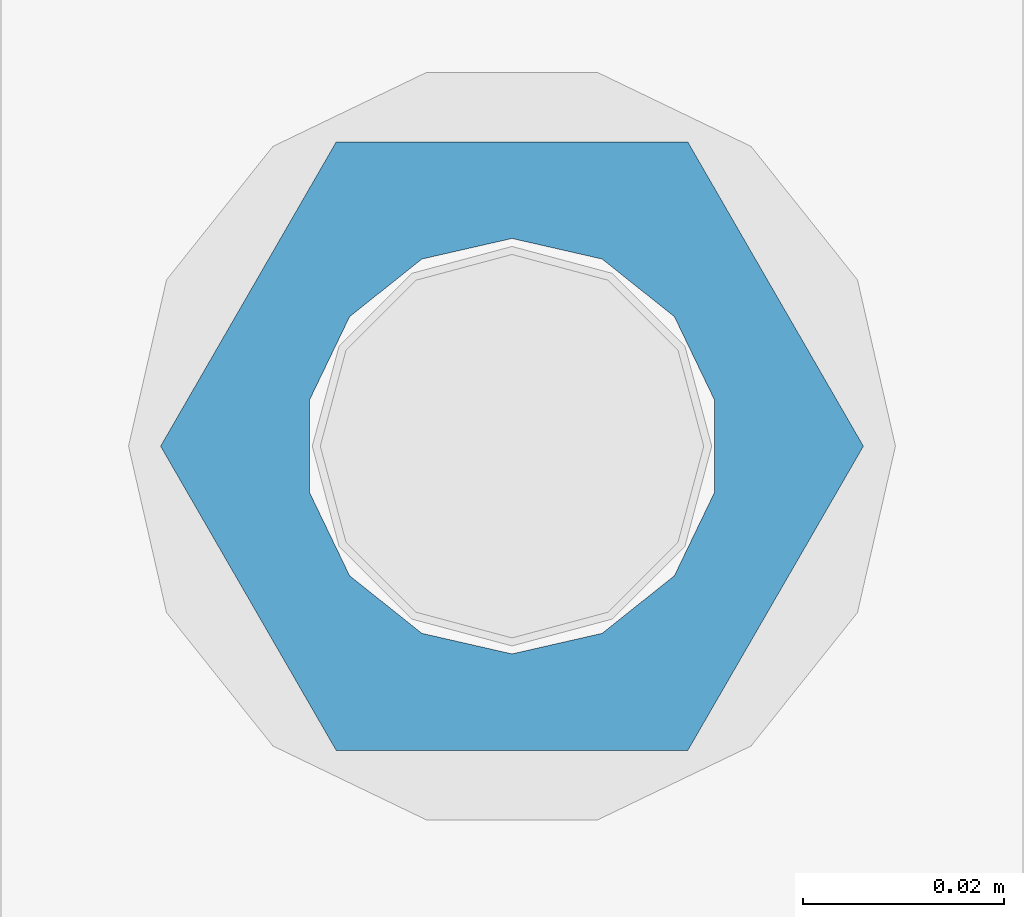
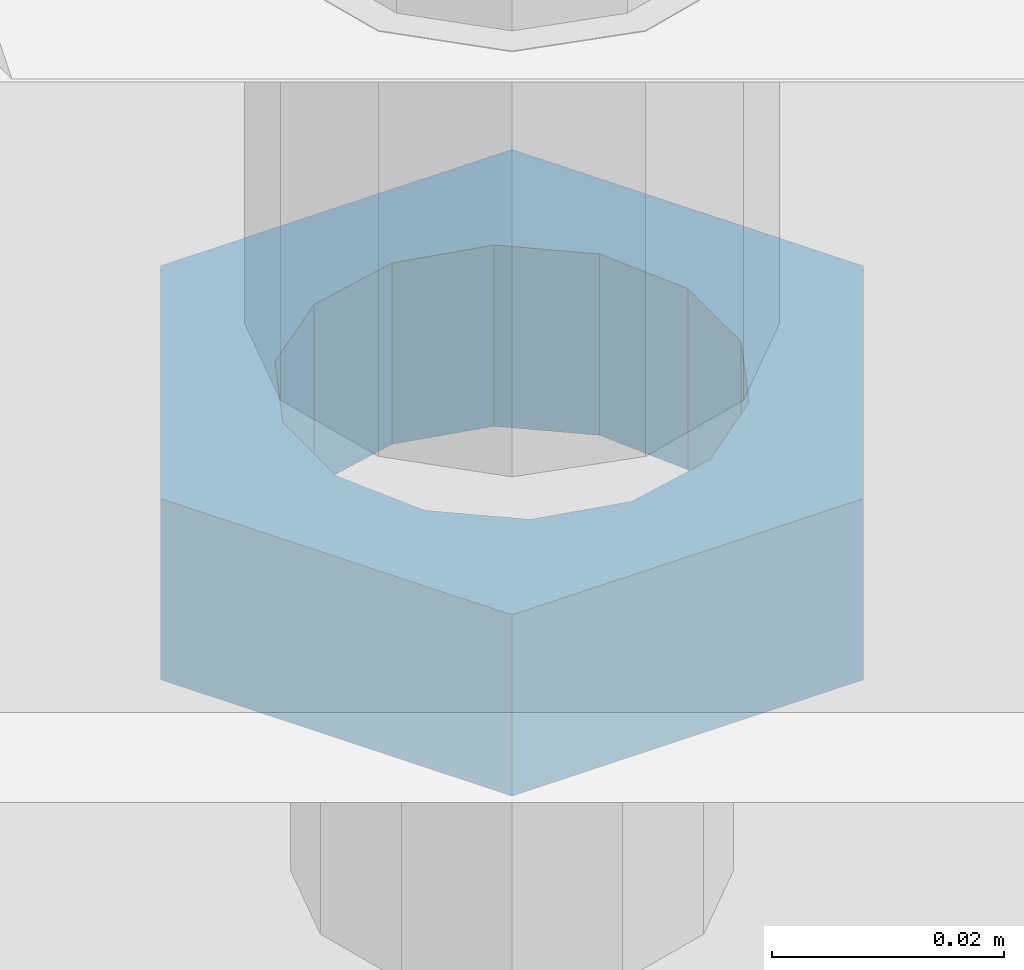
# One storey, part 1391 of 1763: 1 beam, 1 element without a shape of its own.
"""IFC2X3 building model written with IfcOpenShell, lengths in millimetres."""

from ifc_helpers import new_model, si_unit, frame, origin_with_axes, place, context, subcontext, project, spatial, faceted_brep, material, type_object, element, aggregate, save


model = new_model("IFC2X3")

# Units and contexts
model_context = context("Model", 3, precision=1e-05, world=origin_with_axes())
body_context = subcontext(model_context, "Body", "Model", "MODEL_VIEW")
ifc_project = project(units=[si_unit("LENGTHUNIT", "METRE", prefix="MILLI"), si_unit("AREAUNIT", "SQUARE_METRE"), si_unit("VOLUMEUNIT", "CUBIC_METRE"), si_unit("MASSUNIT", "GRAM", prefix="KILO"), si_unit("TIMEUNIT", "SECOND"), si_unit("PLANEANGLEUNIT", "RADIAN"), si_unit("SOLIDANGLEUNIT", "STERADIAN"), si_unit("THERMODYNAMICTEMPERATUREUNIT", "DEGREE_CELSIUS"), si_unit("LUMINOUSINTENSITYUNIT", "LUMEN")], contexts=[model_context])

# Site, building, storey
site_placement = place(None, origin_with_axes())
site = spatial("IfcSite", under=ifc_project, at=site_placement, CompositionType="ELEMENT")
building_placement = place(site_placement, origin_with_axes())
building = spatial("IfcBuilding", under=site, at=building_placement, Name="Undefined", CompositionType="ELEMENT")
storey_placement = place(building_placement, origin_with_axes())
storey = spatial("IfcBuildingStorey", under=building, at=storey_placement, Name="Undefined", CompositionType="ELEMENT", Elevation=0.0)

# Assembly, beam
assembly_placement = place(storey_placement, origin_with_axes())
assembly = element("IfcElementAssembly", 1, at=assembly_placement, inside=storey, Name="TEMPLATE", AssemblyPlace="NOTDEFINED", PredefinedType="RIGID_FRAME")
ifc_material = material(Name="STEEL/A563")
beam_type = type_object("IfcBeamType", Name="1-1/2 DIA. HALF_NUT", PredefinedType="NOTDEFINED")
beam_placement = place(assembly_placement, frame((-87172.2372736984, 8229.60000000001, 5080.00000000001), z_axis=(0.0, 1.0, 0.0), x_axis=(0.0, 0.0, -1.0)))
beam = element("IfcBeam", 2, at=beam_placement, type_object=beam_type, material=ifc_material, Name="NUT", ObjectType="1-1/2 DIA. HALF_NUT", context=body_context, shape_type="Brep", body=[
    faceted_brep([(0.0, -34.9199981689453, 0.0), (0.0, -17.4599990844727, -30.25), (19.0499999999993, -17.4599990844727, -30.25), (19.0499999999993, -34.9199981689453, 0.0), (0.0, 17.4599990844727, -30.25), (19.0499999999993, 17.4599990844727, -30.25), (0.0, 34.9199981689453, 0.0), (19.0499999999993, 34.9199981689453, 0.0), (0.0, 17.4599990844727, 30.25), (19.0499999999993, 17.4599990844727, 30.25), (0.0, -17.4599990844727, 30.25), (19.0499999999993, -17.4599990844727, 30.25), (0.0, 0.0, 20.6399993896484), (0.0, 8.95536011056538, 18.5959968835978), (19.0499999999993, 8.95536011056538, 18.5959968835978), (19.0499999999993, 0.0, 20.6399993896484), (0.0, 16.1370013209453, 12.8688291298167), (19.0499999999993, 16.1370013209453, 12.8688291298167), (0.0, 20.1225115123816, 4.59283194104137), (19.0499999999993, 20.1225115123816, 4.59283194104137), (0.0, 20.1225115123816, -4.59283194104319), (19.0499999999993, 20.1225115123816, -4.59283194104319), (0.0, 16.1370013209453, -12.8688291298167), (19.0499999999993, 16.1370013209453, -12.8688291298167), (0.0, 8.95536011056538, -18.5959968835978), (19.0499999999993, 8.95536011056538, -18.5959968835978), (0.0, 0.0, -20.6399993896484), (19.0499999999993, 0.0, -20.6399993896484), (0.0, -8.95536011056538, -18.5959968835978), (19.0499999999993, -8.95536011056538, -18.5959968835978), (0.0, -16.1370013209453, -12.8688291298167), (19.0499999999993, -16.1370013209453, -12.8688291298167), (0.0, -20.1225115123816, -4.59283194104137), (19.0499999999993, -20.1225115123816, -4.59283194104137), (0.0, -20.1225115123816, 4.59283194104319), (19.0499999999993, -20.1225115123816, 4.59283194104319), (0.0, -16.1370013209453, 12.8688291298167), (19.0499999999993, -16.1370013209453, 12.8688291298167), (0.0, -8.95536011056538, 18.5959968835978), (19.0499999999993, -8.95536011056538, 18.5959968835978)], [[[0, 1, 2, 3]], [[1, 4, 5, 2]], [[4, 6, 7, 5]], [[6, 8, 9, 7]], [[8, 10, 11, 9]], [[10, 0, 3, 11]], [[12, 13, 14, 15]], [[13, 16, 17, 14]], [[16, 18, 19, 17]], [[18, 20, 21, 19]], [[20, 22, 23, 21]], [[22, 24, 25, 23]], [[24, 26, 27, 25]], [[26, 28, 29, 27]], [[28, 30, 31, 29]], [[30, 32, 33, 31]], [[32, 34, 35, 33]], [[34, 36, 37, 35]], [[36, 38, 39, 37]], [[38, 12, 15, 39]], [[5, 7, 9, 11, 3, 2], [17, 19, 21, 23, 25, 27, 29, 31, 33, 35, 37, 39, 15, 14]], [[10, 8, 6, 4, 1, 0], [38, 36, 34, 32, 30, 28, 26, 24, 22, 20, 18, 16, 13, 12]]]),
])
aggregate(assembly, [beam])

save(model, "model.ifc")
